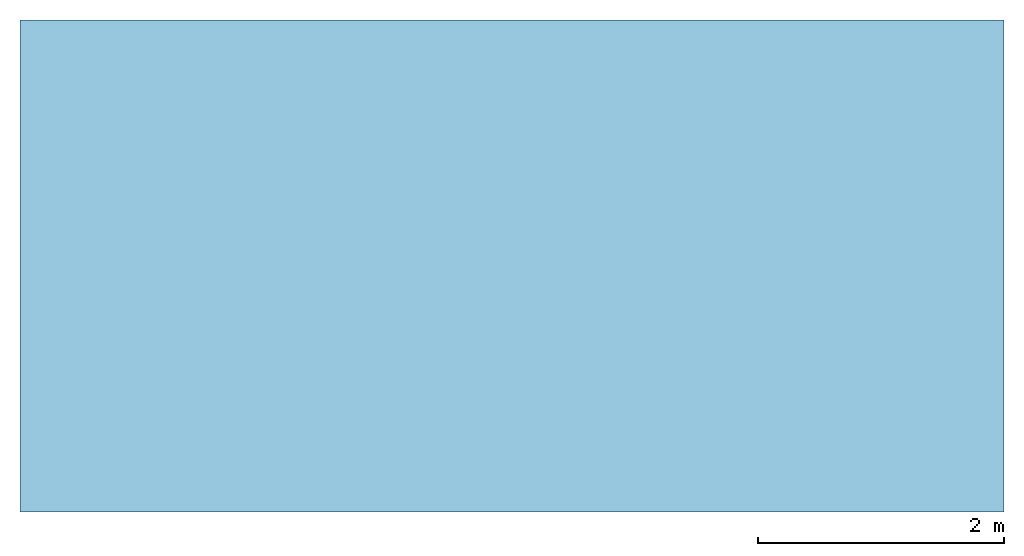
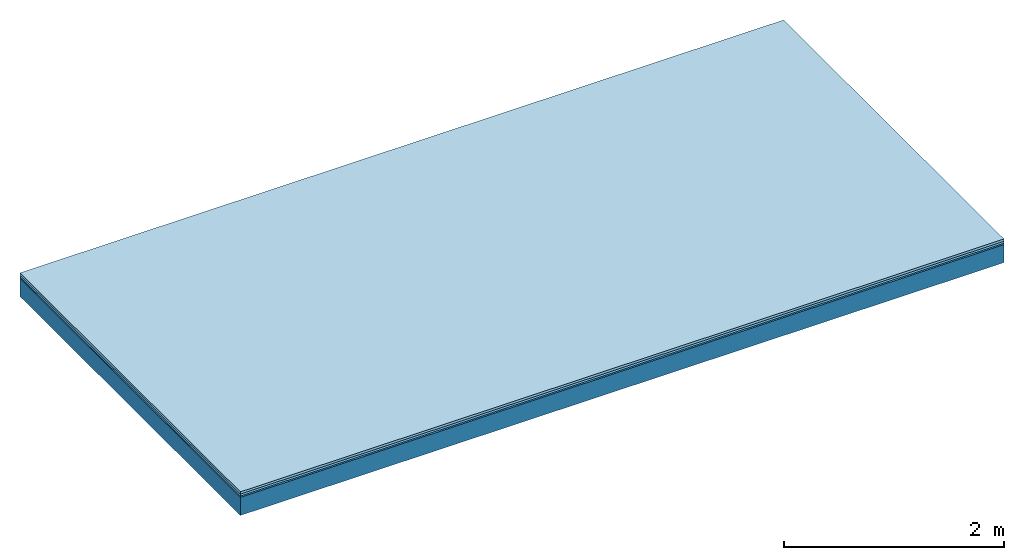
# One storey: 3 plates, 1 member, 1 element without a shape of its own.
"""IFC4 building model written with IfcOpenShell, lengths in metres."""

from ifc_helpers import new_model, si_unit, derived_unit, direction, frame, frame_2d, origin, origin_with_axes, place, context, project, spatial, rectangle, extrude, material, layer, layer_set, type_object, element, aggregate, save


model = new_model("IFC4")

# Units and contexts
plan_context = context("Plan", 3, precision=1e-05, world=origin(), true_north=direction((0.0, 1.0)))
model_context = context("Model", 3, precision=1e-05, world=origin(), true_north=direction((0.0, 1.0)))
ifc_project = project(units=[si_unit("LENGTHUNIT", "METRE"), derived_unit("SOUNDPRESSUREUNIT", [(si_unit("PRESSUREUNIT", "PASCAL", prefix="MICRO"), 0)]), si_unit("ENERGYUNIT", "JOULE", prefix="MEGA"), si_unit("MASSUNIT", "GRAM", prefix="KILO"), derived_unit("THERMALTRANSMITTANCEUNIT", [(si_unit("POWERUNIT", "WATT"), 1), (si_unit("AREAUNIT", "SQUARE_METRE"), -1), (si_unit("THERMODYNAMICTEMPERATUREUNIT", "KELVIN"), -1)]), derived_unit("AREADENSITYUNIT", [(si_unit("MASSUNIT", "GRAM", prefix="KILO"), 1), (si_unit("AREAUNIT", "SQUARE_METRE"), -1)]), derived_unit("USERDEFINED", [(si_unit("ENERGYUNIT", "JOULE", prefix="MEGA"), 1), (si_unit("AREAUNIT", "SQUARE_METRE"), -1)])], contexts=[plan_context, model_context])

# Site, building, storey
site = spatial("IfcSite", under=ifc_project)
building_placement = place(None, origin())
building = spatial("IfcBuilding", under=site, at=building_placement)
storey_placement = place(building_placement, origin())
storey = spatial("IfcBuildingStorey", under=building, at=storey_placement)

# Slab, member, plates
ifc_material_1 = material(Name="Floor heating system Therm38 longitudinal", Category="03.007")
ifc_layer_1 = layer(ifc_material_1, 0.025, Name="On-material")
ifc_material_2 = material(Category="10.009")
ifc_layer_2 = layer(ifc_material_2, 0.022, Name="Impact sound insulation")
ifc_material_3 = material(Category="03.007")
ifc_layer_3 = layer(ifc_material_3, 0.015, Name="on Supporting structure")
ifc_material_4 = material(Name="of the art")
ifc_layer_4 = layer(ifc_material_4, 0.0, Name="Bond")
ifc_layer_5 = layer(None, 0.2, Name="Supporting structure")
ifc_layer_set = layer_set([ifc_layer_1, ifc_layer_2, ifc_layer_3, ifc_layer_4, ifc_layer_5])
slab_type = type_object("IfcSlabType", Name="A0846", PredefinedType="NOTDEFINED", material=ifc_layer_set)
slab_placement = place(None, frame((0.0, 0.0, 0.0), z_axis=(0.0, 0.0, -1.0), x_axis=(1.0, 0.0, 0.0)))
slab = element("IfcSlab", 1, at=slab_placement, inside=storey, type_object=slab_type, material=ifc_layer_set, Name="Slab #1")
ifc_material_5 = material()
member_placement = place(slab_placement, origin())
member = element("IfcMember", 2, at=member_placement, material=ifc_material_5, Name="Supporting structure", context=plan_context, shape_type="SweptSolid", body=[
    extrude(rectangle(XDim=1.0, YDim=0.2, at=frame_2d((0.5, 0.1), x_axis=(1.0, 0.0))), frame((0.0, 4.0, 0.062), z_axis=(0.0, -1.0, 0.0), x_axis=(1.0, 0.0, 0.0)), (0.0, 0.0, 1.0), 4.0),
    extrude(rectangle(XDim=1.0, YDim=0.2, at=frame_2d((0.5, 0.1), x_axis=(1.0, 0.0))), frame((1.0, 4.0, 0.062), z_axis=(0.0, -1.0, 0.0), x_axis=(1.0, 0.0, 0.0)), (0.0, 0.0, 1.0), 4.0),
    extrude(rectangle(XDim=1.0, YDim=0.2, at=frame_2d((0.5, 0.1), x_axis=(1.0, 0.0))), frame((2.0, 4.0, 0.062), z_axis=(0.0, -1.0, 0.0), x_axis=(1.0, 0.0, 0.0)), (0.0, 0.0, 1.0), 4.0),
    extrude(rectangle(XDim=1.0, YDim=0.2, at=frame_2d((0.5, 0.1), x_axis=(1.0, 0.0))), frame((3.0, 4.0, 0.062), z_axis=(0.0, -1.0, 0.0), x_axis=(1.0, 0.0, 0.0)), (0.0, 0.0, 1.0), 4.0),
    extrude(rectangle(XDim=1.0, YDim=0.2, at=frame_2d((0.5, 0.1), x_axis=(1.0, 0.0))), frame((4.0, 4.0, 0.062), z_axis=(0.0, -1.0, 0.0), x_axis=(1.0, 0.0, 0.0)), (0.0, 0.0, 1.0), 4.0),
    extrude(rectangle(XDim=1.0, YDim=0.2, at=frame_2d((0.5, 0.1), x_axis=(1.0, 0.0))), frame((5.0, 4.0, 0.062), z_axis=(0.0, -1.0, 0.0), x_axis=(1.0, 0.0, 0.0)), (0.0, 0.0, 1.0), 4.0),
    extrude(rectangle(XDim=1.0, YDim=0.2, at=frame_2d((0.5, 0.1), x_axis=(1.0, 0.0))), frame((6.0, 4.0, 0.062), z_axis=(0.0, -1.0, 0.0), x_axis=(1.0, 0.0, 0.0)), (0.0, 0.0, 1.0), 4.0),
    extrude(rectangle(XDim=1.0, YDim=0.2, at=frame_2d((0.5, 0.1), x_axis=(1.0, 0.0))), frame((7.0, 4.0, 0.062), z_axis=(0.0, -1.0, 0.0), x_axis=(1.0, 0.0, 0.0)), (0.0, 0.0, 1.0), 4.0),
])
plate_1_placement = place(slab_placement, origin())
plate_1 = element("IfcPlate", 3, at=plate_1_placement, material=ifc_material_1, Name="On-material", context=plan_context, shape_type="SweptSolid", body=[
    extrude(rectangle(XDim=8.0, YDim=4.0, at=frame_2d((4.0, 2.0), x_axis=(1.0, 0.0))), origin_with_axes(), (0.0, 0.0, 1.0), 0.025),
])
plate_2_placement = place(slab_placement, origin())
plate_2 = element("IfcPlate", 4, at=plate_2_placement, material=ifc_material_2, Name="Impact sound insulation", context=plan_context, shape_type="SweptSolid", body=[
    extrude(rectangle(XDim=8.0, YDim=4.0, at=frame_2d((4.0, 2.0), x_axis=(1.0, 0.0))), frame((0.0, 0.0, 0.025), z_axis=(0.0, 0.0, 1.0), x_axis=(1.0, 0.0, 0.0)), (0.0, 0.0, 1.0), 0.022),
])
plate_3_placement = place(slab_placement, origin())
plate_3 = element("IfcPlate", 5, at=plate_3_placement, material=ifc_material_3, Name="on Supporting structure", context=plan_context, shape_type="SweptSolid", body=[
    extrude(rectangle(XDim=8.0, YDim=4.0, at=frame_2d((4.0, 2.0), x_axis=(1.0, 0.0))), frame((0.0, 0.0, 0.047), z_axis=(0.0, 0.0, 1.0), x_axis=(1.0, 0.0, 0.0)), (0.0, 0.0, 1.0), 0.015),
])
aggregate(slab, [plate_1, plate_2, plate_3, member])

save(model, "model.ifc")
